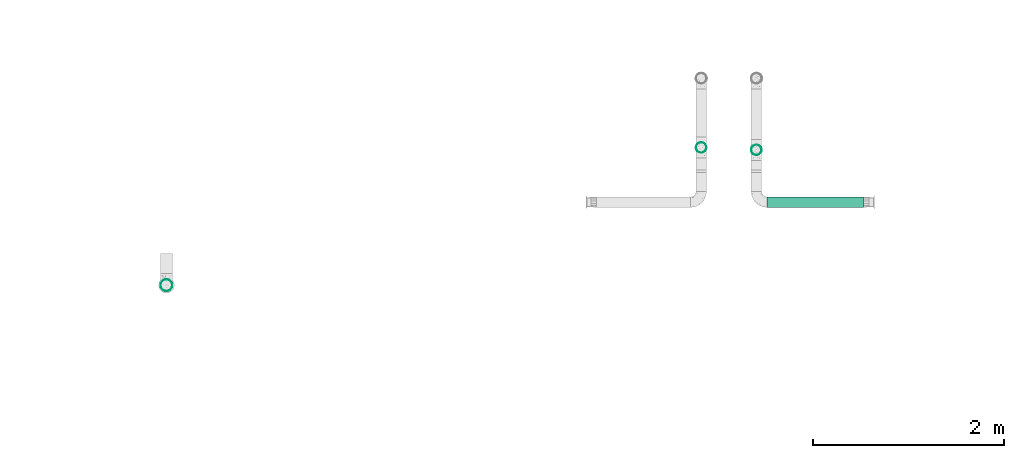
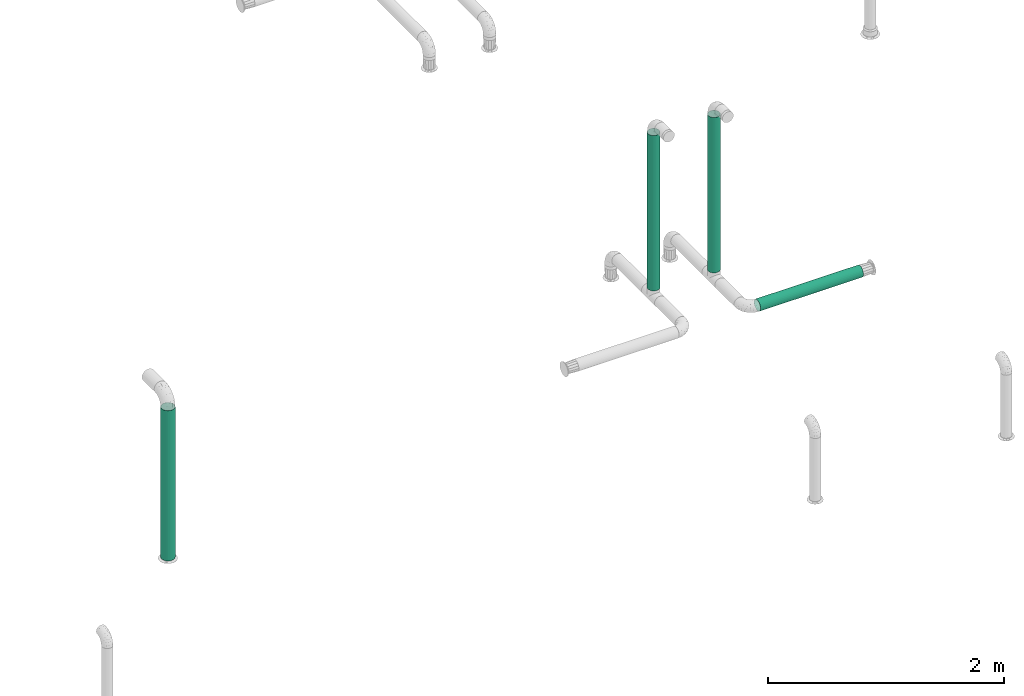
# One storey, part 3 of 103: 4 flow segments.
"""IFC2X3 building model written with IfcOpenShell, lengths in millimetres."""

import ifcopenshell
import ifcopenshell.guid

model = None  # the IFC model being written
_history = None  # IfcOwnerHistory: only IFC2X3 demands one
_inside = {}  # id of a spatial element -> (the spatial element, [elements in it])
_under = {}  # id of a project, library or spatial element -> (it, [spatial elements below it])
_declared = {}  # id of a project -> (the project, [libraries it declares])
_typed = {}  # id of a type object -> (the type object, [elements of that type])
_made_of = {}  # id of a material, layer set ... -> (it, [elements and type objects made of it])


def new_model(schema):
    """Start an empty IFC model of exactly this schema.

    Asked for "IFC4X3", IfcOpenShell would pick the latest addendum, in which some entities
    have other attributes; the version numbers below select the first issue.
    IFC2X3 requires an IfcOwnerHistory on every rooted entity: one is made here for all.
    """
    global model, _history
    if schema == "IFC4X3":
        model = ifcopenshell.file(schema_version=(4, 3, 0, 0))
    else:
        model = ifcopenshell.file(schema=schema)
    _inside.clear()
    _under.clear()
    _declared.clear()
    _typed.clear()
    _made_of.clear()
    _history = None
    if model.schema == "IFC2X3":
        org = make("IfcOrganization", Name="unknown")
        user = make(
            "IfcPersonAndOrganization",
            ThePerson=make("IfcPerson", FamilyName="unknown"),
            TheOrganization=org,
        )
        app = make(
            "IfcApplication",
            ApplicationDeveloper=org,
            Version="unknown",
            ApplicationFullName="unknown",
            ApplicationIdentifier="unknown",
        )
        _history = make(
            "IfcOwnerHistory",
            OwningUser=user,
            OwningApplication=app,
            ChangeAction="ADDED",
            CreationDate=0,
        )
    return model


def make(cls, **values):
    """One entity of the class cls with the attributes given. An attribute that is None is left unset."""
    return model.create_entity(
        cls, **{name: value for name, value in values.items() if value is not None}
    )


def entity(cls, *values):
    """Any entity or typed value of the class cls, its attributes in the order of the schema. None: left unset."""
    e = model.create_entity(cls)
    for i, value in enumerate(values):
        if value is not None:
            e[i] = value
    return e


def rooted(cls, **values):
    """An entity with a GlobalId (a new one), such as an element, a storey or a relation."""
    return make(cls, GlobalId=ifcopenshell.guid.new(), OwnerHistory=_history, **values)


def si_unit(unit_type, name, prefix=None):
    """IfcSIUnit, for example si_unit("LENGTHUNIT", "METRE", prefix="MILLI")."""
    return make("IfcSIUnit", UnitType=unit_type, Prefix=prefix, Name=name)


def converted_unit(unit_type, name, factor, base, dimensions=None, offset=None):
    """IfcConversionBasedUnit, such as the inch: factor (a typed value) times the base unit."""
    return make(
        "IfcConversionBasedUnit"
        if offset is None
        else "IfcConversionBasedUnitWithOffset",
        ConversionOffset=offset,
        Dimensions=None
        if dimensions is None
        else entity("IfcDimensionalExponents", *dimensions),
        UnitType=unit_type,
        Name=name,
        ConversionFactor=make(
            "IfcMeasureWithUnit", ValueComponent=factor, UnitComponent=base
        ),
    )


def derived_unit(unit_type, elements):
    """IfcDerivedUnit: a product of units, each with its exponent."""
    return make(
        "IfcDerivedUnit",
        Elements=[
            make("IfcDerivedUnitElement", Unit=unit, Exponent=power)
            for unit, power in elements
        ],
        UnitType=unit_type,
    )


def assignment(units):
    """IfcUnitAssignment: the units of a project."""
    return None if units is None else make("IfcUnitAssignment", Units=units)


def point(xyz):
    """IfcCartesianPoint."""
    return None if xyz is None else make("IfcCartesianPoint", Coordinates=xyz)


def direction(xyz):
    """IfcDirection."""
    return None if xyz is None else make("IfcDirection", DirectionRatios=xyz)


def frame(location, z_axis=None, x_axis=None):
    """IfcAxis2Placement3D, a coordinate frame: its origin and axes. An axis left out is left unset."""
    return make(
        "IfcAxis2Placement3D",
        Location=point(location),
        Axis=direction(z_axis),
        RefDirection=direction(x_axis),
    )


def frame_2d(location, x_axis=None):
    """IfcAxis2Placement2D, a coordinate frame in the plane: its origin and x axis."""
    return make(
        "IfcAxis2Placement2D", Location=point(location), RefDirection=direction(x_axis)
    )


def origin_with_axes():
    """The frame at (0, 0, 0) with the z axis (0, 0, 1) and the x axis (1, 0, 0) written out."""
    return frame((0.0, 0.0, 0.0), z_axis=(0.0, 0.0, 1.0), x_axis=(1.0, 0.0, 0.0))


def origin_2d_with_axis():
    """The frame at (0, 0) in the plane with the x axis (1, 0) written out."""
    return frame_2d((0.0, 0.0), x_axis=(1.0, 0.0))


def place(relative_to, where):
    """IfcLocalPlacement: puts the frame where relative to a parent placement (None: the world)."""
    return make(
        "IfcLocalPlacement", PlacementRelTo=relative_to, RelativePlacement=where
    )


def context(
    kind, dimensions, precision=None, world=None, true_north=None, identifier=None
):
    """IfcGeometricRepresentationContext, for example the 3D "Model" context."""
    return make(
        "IfcGeometricRepresentationContext",
        ContextIdentifier=identifier,
        ContextType=kind,
        CoordinateSpaceDimension=dimensions,
        Precision=precision,
        WorldCoordinateSystem=world,
        TrueNorth=true_north,
    )


def subcontext(parent, identifier, kind, view, scale=None):
    """IfcGeometricRepresentationSubContext, for example "Body" below "Model"."""
    return make(
        "IfcGeometricRepresentationSubContext",
        ContextIdentifier=identifier,
        ContextType=kind,
        ParentContext=parent,
        TargetScale=scale,
        TargetView=view,
    )


def project(units=None, contexts=None):
    """IfcProject with its units and contexts."""
    return rooted(
        "IfcProject",
        Name="project",
        RepresentationContexts=contexts,
        UnitsInContext=assignment(units),
    )


def spatial(cls, under=None, at=None, **own):
    """A site, building, storey or space (cls), placed at a placement, below another one or the project."""
    s = rooted(cls, ObjectPlacement=at, **own)
    if under is not None:
        _under.setdefault(under.id(), (under, []))[1].append(s)
    return s


def profile(cls, at=None, kind="AREA", **sizes):
    """A parametric profile (cls). Its sizes go by their IFC names, for example OverallWidth=200.0."""
    return make(cls, ProfileType=kind, Position=at, **sizes)


def hollow_circle(**sizes):
    """IfcCircleHollowProfileDef."""
    return profile("IfcCircleHollowProfileDef", **sizes)


def extrude(swept, where, along, depth):
    """IfcExtrudedAreaSolid: the profile swept, set in the frame where, extruded along a direction by depth."""
    return make(
        "IfcExtrudedAreaSolid",
        SweptArea=swept,
        Position=where,
        ExtrudedDirection=direction(along),
        Depth=depth,
    )


def shape(context_of_items, identifier, shape_type, items):
    """IfcShapeRepresentation: the items that make up one representation, for example the "Body"."""
    return make(
        "IfcShapeRepresentation",
        ContextOfItems=context_of_items,
        RepresentationIdentifier=identifier,
        RepresentationType=shape_type,
        Items=items,
    )


def source(mapping_origin, context_of_items, identifier, shape_type, items):
    """IfcRepresentationMap: a shape defined once, which mapped items show again and again."""
    return make(
        "IfcRepresentationMap",
        MappingOrigin=mapping_origin,
        MappedRepresentation=shape(context_of_items, identifier, shape_type, items),
    )


def transform(
    local_origin,
    x_axis=None,
    y_axis=None,
    z_axis=None,
    scale=None,
    scale2=None,
    scale3=None,
    uniform=True,
):
    """IfcCartesianTransformationOperator3D, or its non-uniform kind. x_axis, y_axis, z_axis: its Axis1, 2, 3."""
    if uniform:
        return make(
            "IfcCartesianTransformationOperator3D",
            Axis1=direction(x_axis),
            Axis2=direction(y_axis),
            LocalOrigin=point(local_origin),
            Scale=scale,
            Axis3=direction(z_axis),
        )
    return make(
        "IfcCartesianTransformationOperator3DnonUniform",
        Axis1=direction(x_axis),
        Axis2=direction(y_axis),
        LocalOrigin=point(local_origin),
        Scale=scale,
        Axis3=direction(z_axis),
        Scale2=scale2,
        Scale3=scale3,
    )


def mapped(mapping_source, mapping_target):
    """IfcMappedItem: shows the shape of a source again, moved by a transform."""
    return make(
        "IfcMappedItem", MappingSource=mapping_source, MappingTarget=mapping_target
    )


def material(Name=None, Category=None):
    """IfcMaterial."""
    return make("IfcMaterial", Name=Name, Category=Category)


def layer(
    of_material, thickness, ventilated=None, Name=None, Category=None, Priority=None
):
    """IfcMaterialLayer: one layer of a wall or slab, of a material (None: an air gap)."""
    return make(
        "IfcMaterialLayer",
        Material=of_material,
        LayerThickness=thickness,
        IsVentilated=ventilated,
        Name=Name,
        Category=Category,
        Priority=Priority,
    )


def layer_set(layers, Name=None):
    """IfcMaterialLayerSet."""
    return make("IfcMaterialLayerSet", MaterialLayers=layers, LayerSetName=Name)


def layer_usage(for_layer_set, set_direction, sense, offset, extent=None):
    """IfcMaterialLayerSetUsage: how a layer set lies in its element."""
    return make(
        "IfcMaterialLayerSetUsage",
        ForLayerSet=for_layer_set,
        LayerSetDirection=set_direction,
        DirectionSense=sense,
        OffsetFromReferenceLine=offset,
        ReferenceExtent=extent,
    )


def made_of(thing, what):
    """Note that an element or type object is made of a material, layer set ...; save() writes the relation."""
    if what is not None:
        _made_of.setdefault(what.id(), (what, []))[1].append(thing)
    return thing


def type_object(cls, material=None, **own):
    """A type object (cls), such as IfcWallType, which elements share."""
    return made_of(rooted(cls, **own), material)


def element(
    cls,
    number,
    at=None,
    inside=None,
    cuts=None,
    type_object=None,
    material=None,
    context=None,
    identifier="Body",
    shape_type=None,
    held_by="IfcProductDefinitionShape",
    body=None,
    shapes=None,
    **own,
):
    """One element of the class cls, such as IfcWall. Its Tag is "e" and its number.

    at: its placement. inside: the storey or other place that contains it. cuts: it is an
    opening in that element (IfcRelVoidsElement). A single representation is given by context,
    identifier, shape_type and body (its items); several are given by shapes. held_by: the class
    of the entity that holds the representations. save() writes the other relations.
    """
    e = rooted(cls, Tag="e%d" % number, ObjectPlacement=at, **own)
    if body is not None:
        shapes = [shape(context, identifier, shape_type, body)]
    if shapes is not None:
        e.Representation = make(held_by, Representations=shapes)
    if inside is not None:
        _inside.setdefault(inside.id(), (inside, []))[1].append(e)
    if cuts is not None:
        rooted(
            "IfcRelVoidsElement", RelatingBuildingElement=cuts, RelatedOpeningElement=e
        )
    if type_object is not None:
        _typed.setdefault(type_object.id(), (type_object, []))[1].append(e)
    return made_of(e, material)


def aggregate(whole, parts):
    """IfcRelAggregates: a whole, such as a stair, and the parts it consists of."""
    return rooted("IfcRelAggregates", RelatingObject=whole, RelatedObjects=parts)


def save(model, path):
    """Write the relations noted so far, then the file.

    IfcRelAggregates (storeys below a building ...), IfcRelContainedInSpatialStructure (elements
    in a storey), IfcRelDefinesByType, IfcRelAssociatesMaterial and IfcRelDeclares: one each for
    every whole, place, type object, material and project.
    """
    for whole, parts in _under.values():
        aggregate(whole, parts)
    for where, things in _inside.values():
        rooted(
            "IfcRelContainedInSpatialStructure",
            RelatedElements=things,
            RelatingStructure=where,
        )
    for kind, things in _typed.values():
        rooted("IfcRelDefinesByType", RelatedObjects=things, RelatingType=kind)
    for what, things in _made_of.values():
        rooted("IfcRelAssociatesMaterial", RelatedObjects=things, RelatingMaterial=what)
    for by, libraries in _declared.values():
        rooted("IfcRelDeclares", RelatingContext=by, RelatedDefinitions=libraries)
    model.write(path)


model = new_model("IFC2X3")

# Units and contexts
model_context = context("Model", 3, precision=1e-05, world=origin_with_axes(), true_north=direction((0.0, 1.0)))
body_context = subcontext(model_context, "Body", "Model", "MODEL_VIEW")
ifc_project = project(units=[si_unit("AREAUNIT", "SQUARE_METRE"), si_unit("VOLUMEUNIT", "CUBIC_METRE", prefix="DECI"), si_unit("TIMEUNIT", "SECOND"), si_unit("THERMODYNAMICTEMPERATUREUNIT", "DEGREE_CELSIUS"), si_unit("PRESSUREUNIT", "PASCAL"), si_unit("MASSUNIT", "GRAM", prefix="KILO"), si_unit("LENGTHUNIT", "METRE", prefix="MILLI"), si_unit("POWERUNIT", "WATT"), si_unit("ELECTRICCURRENTUNIT", "AMPERE"), si_unit("ELECTRICVOLTAGEUNIT", "VOLT"), derived_unit("VOLUMETRICFLOWRATEUNIT", [(si_unit("VOLUMEUNIT", "CUBIC_METRE", prefix="DECI"), 1), (si_unit("TIMEUNIT", "SECOND"), -1)]), derived_unit("LINEARVELOCITYUNIT", [(si_unit("LENGTHUNIT", "METRE"), 1), (si_unit("TIMEUNIT", "SECOND"), -1)]), derived_unit("MASSDENSITYUNIT", [(si_unit("MASSUNIT", "GRAM", prefix="KILO"), 1), (si_unit("VOLUMEUNIT", "CUBIC_METRE"), -1)]), converted_unit("PLANEANGLEUNIT", "DEGREE", entity("IfcRatioMeasure", 0.01745), si_unit("PLANEANGLEUNIT", "RADIAN"), dimensions=[0, 0, 0, 0, 0, 0, 0])], contexts=[model_context])

# Site, building, storey
site_placement = place(None, origin_with_axes())
site = spatial("IfcSite", under=ifc_project, at=site_placement, CompositionType="ELEMENT")
building_placement = place(site_placement, origin_with_axes())
building = spatial("IfcBuilding", under=site, at=building_placement, Name="mc-building", CompositionType="ELEMENT")
storey_placement = place(building_placement, frame((0.0, 0.0, 5900.0), z_axis=(0.0, 0.0, 1.0), x_axis=(1.0, 0.0, 0.0)))
storey = spatial("IfcBuildingStorey", under=building, at=storey_placement, Name="3. Korrus", CompositionType="ELEMENT", Elevation=5900.0)

# Flow segments
ifc_material = material(Name="FZ1")
ifc_layer = layer(ifc_material, 0.0)
ifc_layer_set = layer_set([ifc_layer], Name="FZ1")
ifc_layer_usage = layer_usage(ifc_layer_set, "AXIS1", "POSITIVE", 0.0)
duct_segment_type = type_object("IfcDuctSegmentType", Name="Safe", PredefinedType="RIGIDSEGMENT")
shared_shape_1 = source(origin_with_axes(), body_context, "Body", "SweptSolid", [
    extrude(hollow_circle(Radius=55.0, WallThickness=2.0, at=origin_2d_with_axis()), frame((0.0, 0.0, 0.0), z_axis=(1.0, 0.0, 0.0), x_axis=(0.0, 1.0, 0.0)), (0.0, 0.0, 1.0), 1609.0),
])
for number, where, z_axis, x_axis, name in (
    (1, (26665.96154, 3982.48523, 2425.0), (0.0, -1.0, 0.0), (0.0, 0.0, 1.0), "Safe"),
    (2, (26088.96136, 4007.31628, 2425.0), (0.0, -1.0, 0.0), (0.0, 0.0, 1.0), "Safe"),
):
    element("IfcFlowSegment", number, at=place(storey_placement, frame(where, z_axis=z_axis, x_axis=x_axis)), inside=storey, type_object=duct_segment_type, material=ifc_layer_usage, Name=name, context=body_context, shape_type="MappedRepresentation", body=[
        mapped(shared_shape_1, transform((0.0, 0.0, 0.0), scale=1.0)),
    ])
shared_shape_2 = source(origin_with_axes(), body_context, "Body", "SweptSolid", [
    extrude(hollow_circle(Radius=55.0, WallThickness=2.0, at=origin_2d_with_axis()), frame((0.0, 0.0, 0.0), z_axis=(1.0, 0.0, 0.0), x_axis=(0.0, 1.0, 0.0)), (0.0, 0.0, 1.0), 1007.9),
])
flow_segment_1_placement = place(storey_placement, frame((26775.96154, 3436.80698, 2345.0), z_axis=(0.0, 0.0, 1.0), x_axis=(1.0, 0.0, 0.0)))
element("IfcFlowSegment", 3, at=flow_segment_1_placement, inside=storey, type_object=duct_segment_type, material=ifc_layer_usage, Name="Safe", context=body_context, shape_type="MappedRepresentation", body=[
    mapped(shared_shape_2, transform((0.0, 0.0, 0.0), scale=1.0)),
])
shared_shape_3 = source(origin_with_axes(), body_context, "Body", "SweptSolid", [
    extrude(hollow_circle(Radius=62.5, WallThickness=2.0, at=origin_2d_with_axis()), frame((0.0, 0.0, 0.0), z_axis=(1.0, 0.0, 0.0), x_axis=(0.0, 1.0, 0.0)), (0.0, 0.0, 1.0), 1555.9),
])
flow_segment_2_placement = place(storey_placement, frame((20500.0937, 2567.93182, 2463.1), z_axis=(1.0, 0.0, 0.0), x_axis=(0.0, 0.0, 1.0)))
element("IfcFlowSegment", 4, at=flow_segment_2_placement, inside=storey, type_object=duct_segment_type, material=ifc_layer_usage, Name="Safe", context=body_context, shape_type="MappedRepresentation", body=[
    mapped(shared_shape_3, transform((0.0, 0.0, 0.0), scale=1.0)),
])

save(model, "model.ifc")
